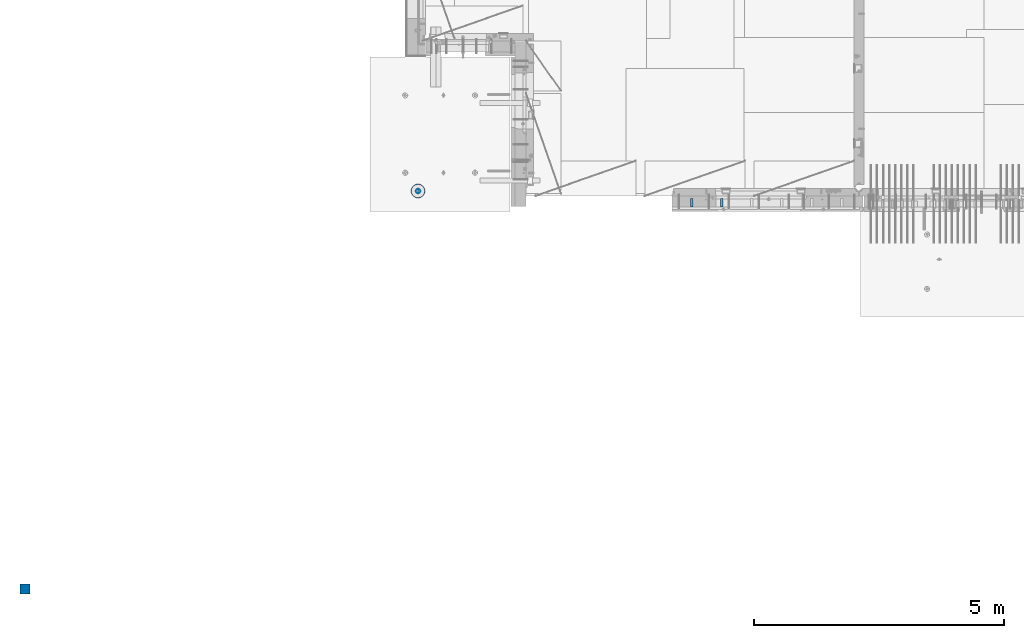
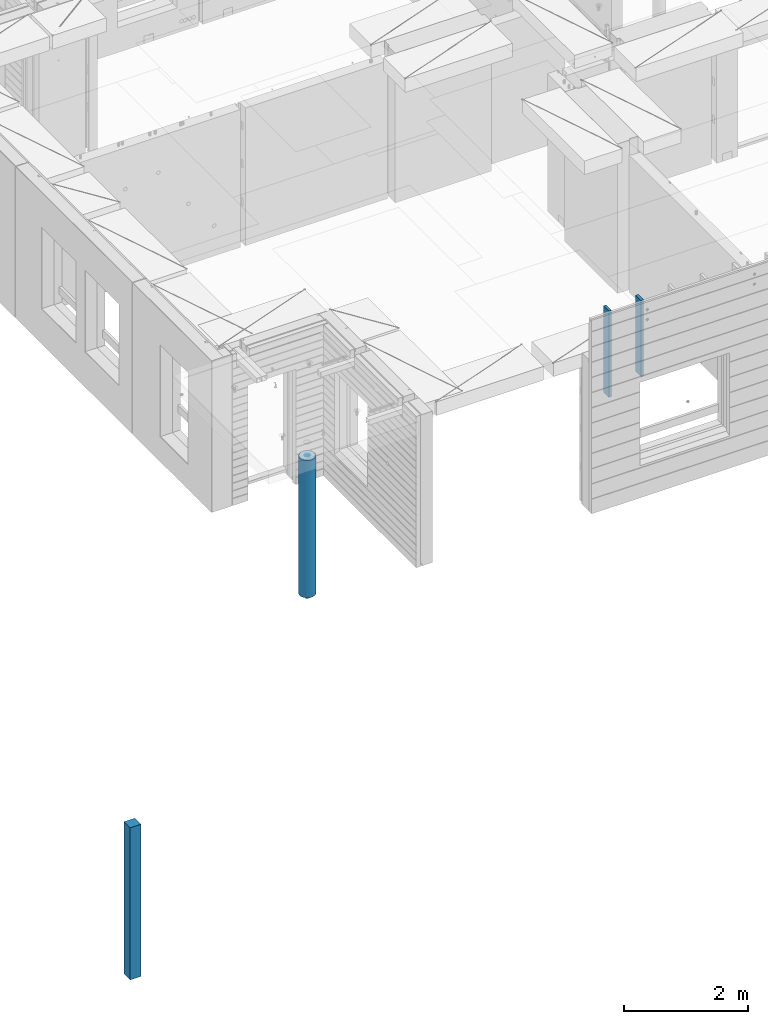
# One storey, part 1 of 309: 4 columns, 3 elements without a shape of their own.
"""IFC2X3 building model written with IfcOpenShell, lengths in millimetres."""

from ifc_helpers import new_model, si_unit, frame, origin_with_axes, place, context, subcontext, project, spatial, faceted_brep, material, type_object, element, aggregate, save


model = new_model("IFC2X3")

# Units and contexts
model_context = context("Model", 3, precision=1e-05, world=origin_with_axes())
body_context = subcontext(model_context, "Body", "Model", "MODEL_VIEW")
ifc_project = project(units=[si_unit("LENGTHUNIT", "METRE", prefix="MILLI"), si_unit("AREAUNIT", "SQUARE_METRE"), si_unit("VOLUMEUNIT", "CUBIC_METRE"), si_unit("MASSUNIT", "GRAM", prefix="KILO"), si_unit("TIMEUNIT", "SECOND"), si_unit("PLANEANGLEUNIT", "RADIAN"), si_unit("SOLIDANGLEUNIT", "STERADIAN"), si_unit("THERMODYNAMICTEMPERATUREUNIT", "DEGREE_CELSIUS"), si_unit("LUMINOUSINTENSITYUNIT", "LUMEN")], contexts=[model_context])

# Site, building, storey
site_placement = place(None, origin_with_axes())
site = spatial("IfcSite", under=ifc_project, at=site_placement, CompositionType="ELEMENT")
building_placement = place(site_placement, origin_with_axes())
building = spatial("IfcBuilding", under=site, at=building_placement, CompositionType="ELEMENT")
storey_placement = place(building_placement, origin_with_axes())
storey = spatial("IfcBuildingStorey", under=building, at=storey_placement, Name="7", CompositionType="ELEMENT", Elevation=0.0)

# Assembly, columns
assembly_1_placement = place(storey_placement, origin_with_axes())
assembly_1 = element("IfcElementAssembly", 1, at=assembly_1_placement, inside=storey, AssemblyPlace="NOTDEFINED", PredefinedType="REINFORCEMENT_UNIT")
ifc_material_1 = material(Name="TIMBER/T24")
column_type_1 = type_object("IfcColumnType", Name="PK50X175", PredefinedType="NOTDEFINED")
column_1_placement = place(assembly_1_placement, frame((13315.0, 7717.5, 101870.0), z_axis=(0.0, 1.0, 0.0), x_axis=(0.0, 0.0, 1.0)))
column_1 = element("IfcColumn", 2, at=column_1_placement, type_object=column_type_1, material=ifc_material_1, ObjectType="PK50X175", context=body_context, shape_type="Brep", body=[
    faceted_brep([(0.0, 25.0, 87.5), (0.0, -25.0, 87.5), (1700.0, -25.0, 87.5), (1700.0, 25.0, 87.5), (0.0, -25.0, -87.5), (1700.0, -25.0, -87.5), (0.0, 25.0, -87.5), (1700.0, 25.0, -87.5)], [[[0, 1, 2, 3]], [[1, 4, 5, 2]], [[4, 6, 7, 5]], [[6, 0, 3, 7]], [[5, 7, 3, 2]], [[6, 4, 1, 0]]]),
])
column_2_placement = place(assembly_1_placement, frame((13915.0, 7717.5, 102065.0), z_axis=(0.0, 1.0, 0.0), x_axis=(0.0, 0.0, 1.0)))
column_2 = element("IfcColumn", 3, at=column_2_placement, type_object=column_type_1, material=ifc_material_1, ObjectType="PK50X175", context=body_context, shape_type="Brep", body=[
    faceted_brep([(0.0, 25.0, 87.5), (0.0, -25.0, 87.5), (1505.0, -25.0, 87.5), (1505.0, 25.0, 87.5), (0.0, -25.0, -87.5), (1505.0, -25.0, -87.5), (0.0, 25.0, -87.5), (1505.0, 25.0, -87.5)], [[[0, 1, 2, 3]], [[1, 4, 5, 2]], [[4, 6, 7, 5]], [[6, 0, 3, 7]], [[5, 7, 3, 2]], [[6, 4, 1, 0]]]),
])
aggregate(assembly_1, [column_1, column_2])

# Assembly, column
assembly_2_placement = place(storey_placement, origin_with_axes())
assembly_2 = element("IfcElementAssembly", 4, at=assembly_2_placement, inside=storey, AssemblyPlace="NOTDEFINED", PredefinedType="REINFORCEMENT_UNIT")
ifc_material_2 = material(Name="CONCRETE/Concrete_Undefined")
column_type_2 = type_object("IfcColumnType", PredefinedType="NOTDEFINED")
column_3_placement = place(assembly_2_placement, frame((0.0, 0.0, 99760.0), z_axis=(0.0, 1.0, 0.0), x_axis=(0.0, 0.0, 1.0)))
column_3 = element("IfcColumn", 5, at=column_3_placement, type_object=column_type_2, material=ifc_material_2, context=body_context, shape_type="Brep", body=[
    faceted_brep([(0.0, 100.0, -100.0), (0.0, 100.0, 100.0), (3000.0, 100.0, 100.0), (3000.0, 100.0, -100.0), (0.0, -100.0, 100.0), (3000.0, -100.0, 100.0), (0.0, -100.0, -100.0), (3000.0, -100.0, -100.0)], [[[0, 1, 2, 3]], [[1, 4, 5, 2]], [[4, 6, 7, 5]], [[6, 0, 3, 7]], [[5, 7, 3, 2]], [[6, 4, 1, 0]]]),
])
aggregate(assembly_2, [column_3])

assembly_3_placement = place(storey_placement, origin_with_axes())
assembly_3 = element("IfcElementAssembly", 6, at=assembly_3_placement, inside=storey, AssemblyPlace="NOTDEFINED", PredefinedType="REINFORCEMENT_UNIT")
ifc_material_3 = material(Name="CONCRETE/C30/37")
column_type_3 = type_object("IfcColumnType", Name="D280", PredefinedType="NOTDEFINED")
column_4_placement = place(assembly_3_placement, frame((7849.99879520436, 7949.98488883804, 99725.0), z_axis=(-1.0, 3.00000001838171e-08, 0.0), x_axis=(0.0, 0.0, 1.0)))
column_4 = element("IfcColumn", 7, at=column_4_placement, type_object=column_type_3, material=ifc_material_3, ObjectType="D280", context=body_context, shape_type="Brep", body=[
    faceted_brep([(0.0, -140.0, 0.0), (0.0, -136.489907705454, -31.1529307538876), (2710.0, -136.489907705454, -31.1529307538876), (2710.0, -140.0, 0.0), (0.0, -126.135641506338, -60.7437234764584), (2710.0, -126.135641506338, -60.7437234764584), (0.0, -109.456407545524, -87.2885722602223), (2710.0, -109.456407545524, -87.2885722602223), (0.0, -87.2885722602223, -109.456407545527), (2710.0, -87.2885722602223, -109.456407545527), (0.0, -60.7437234764584, -126.135641506342), (2710.0, -60.7437234764584, -126.135641506342), (0.0, -31.152930753884, -136.489907705458), (2710.0, -31.152930753884, -136.489907705458), (0.0, 0.0, -140.0), (2710.0, 0.0, -140.0), (0.0, 31.152930753884, -136.489907705458), (2710.0, 31.152930753884, -136.489907705458), (0.0, 60.7437234764584, -126.135641506342), (2710.0, 60.7437234764584, -126.135641506342), (0.0, 87.2885722602223, -109.456407545527), (2710.0, 87.2885722602223, -109.456407545527), (0.0, 109.456407545524, -87.2885722602223), (2710.0, 109.456407545524, -87.2885722602223), (0.0, 126.135641506338, -60.7437234764584), (2710.0, 126.135641506338, -60.7437234764584), (0.0, 136.489907705454, -31.1529307538876), (2710.0, 136.489907705454, -31.1529307538876), (0.0, 140.0, 0.0), (2710.0, 140.0, 0.0), (0.0, 136.489907705454, 31.1529307538876), (2710.0, 136.489907705454, 31.1529307538876), (0.0, 126.135641506338, 60.7437234764584), (2710.0, 126.135641506338, 60.7437234764584), (0.0, 109.456407545524, 87.2885722602223), (2710.0, 109.456407545524, 87.2885722602223), (0.0, 87.2885722602223, 109.456407545527), (2710.0, 87.2885722602223, 109.456407545527), (0.0, 60.7437234764584, 126.135641506342), (2710.0, 60.7437234764584, 126.135641506342), (0.0, 31.152930753884, 136.489907705458), (2710.0, 31.152930753884, 136.489907705458), (0.0, 0.0, 140.0), (2710.0, 0.0, 140.0), (0.0, -31.152930753884, 136.489907705458), (2710.0, -31.152930753884, 136.489907705458), (0.0, -60.7437234764584, 126.135641506342), (2710.0, -60.7437234764584, 126.135641506342), (0.0, -87.2885722602223, 109.456407545527), (2710.0, -87.2885722602223, 109.456407545527), (0.0, -109.456407545524, 87.2885722602223), (2710.0, -109.456407545524, 87.2885722602223), (0.0, -126.135641506338, 60.7437234764584), (2710.0, -126.135641506338, 60.7437234764584), (0.0, -136.489907705454, 31.1529307538876), (2710.0, -136.489907705454, 31.1529307538876)], [[[0, 1, 2, 3]], [[1, 4, 5, 2]], [[4, 6, 7, 5]], [[6, 8, 9, 7]], [[8, 10, 11, 9]], [[10, 12, 13, 11]], [[12, 14, 15, 13]], [[14, 16, 17, 15]], [[16, 18, 19, 17]], [[18, 20, 21, 19]], [[20, 22, 23, 21]], [[22, 24, 25, 23]], [[24, 26, 27, 25]], [[26, 28, 29, 27]], [[28, 30, 31, 29]], [[30, 32, 33, 31]], [[32, 34, 35, 33]], [[34, 36, 37, 35]], [[36, 38, 39, 37]], [[38, 40, 41, 39]], [[40, 42, 43, 41]], [[42, 44, 45, 43]], [[44, 46, 47, 45]], [[46, 48, 49, 47]], [[48, 50, 51, 49]], [[50, 52, 53, 51]], [[52, 54, 55, 53]], [[54, 0, 3, 55]], [[5, 7, 9, 11, 13, 15, 17, 19, 21, 23, 25, 27, 29, 31, 33, 35, 37, 39, 41, 43, 45, 47, 49, 51, 53, 55, 3, 2]], [[54, 52, 50, 48, 46, 44, 42, 40, 38, 36, 34, 32, 30, 28, 26, 24, 22, 20, 18, 16, 14, 12, 10, 8, 6, 4, 1, 0]]]),
])
aggregate(assembly_3, [column_4])

save(model, "model.ifc")
